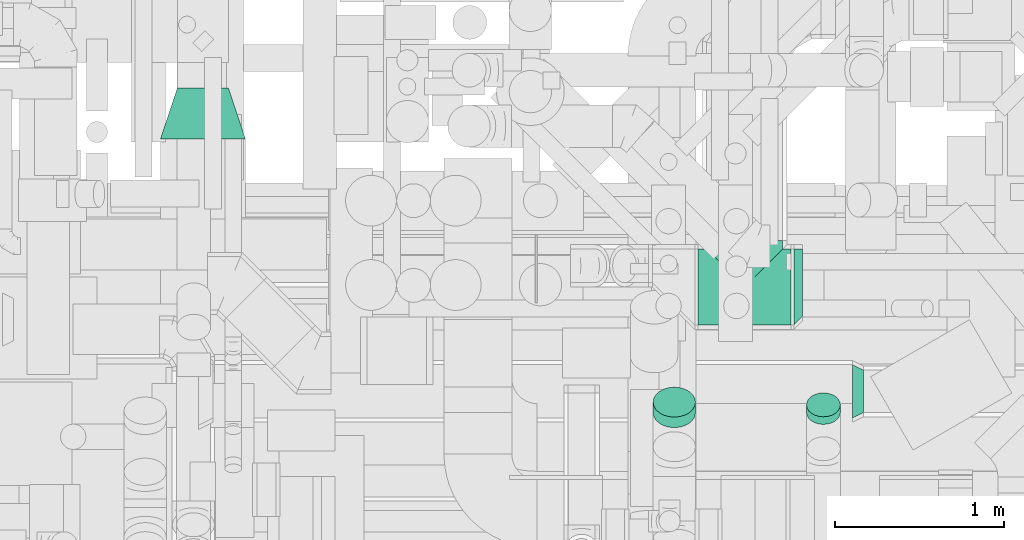
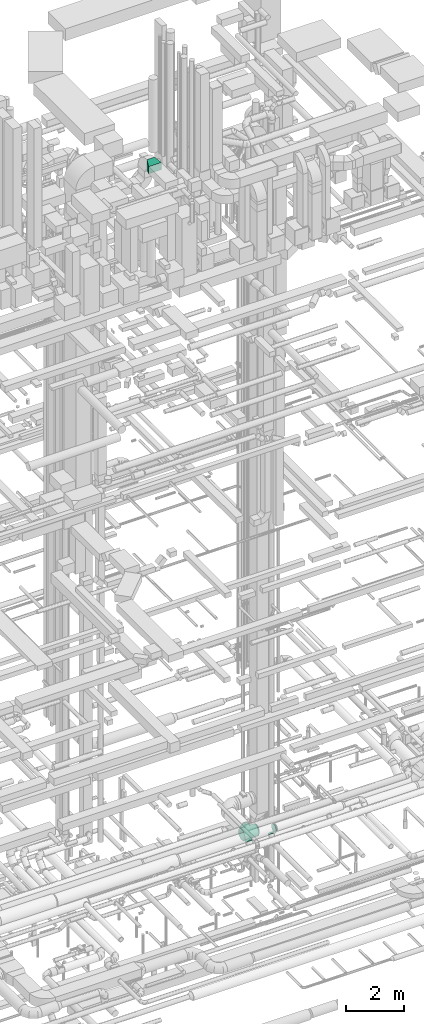
# One storey, part 327 of 337: 6 flow fittings.
"""IFC2X3 building model written with IfcOpenShell, lengths in millimetres."""

from ifc_helpers import new_model, entity, si_unit, converted_unit, derived_unit, direction, frame, origin, place, context, subcontext, project, spatial, faceted_brep, source, transform, mapped, material, type_object, type_shapes, element, save


model = new_model("IFC2X3")

# Units and contexts
model_context = context("Model", 3, precision=0.01, world=origin(), true_north=direction((6.12303176911189e-17, 1.0)))
body_context = subcontext(model_context, "Body", "Model", "MODEL_VIEW")
ifc_project = project(units=[si_unit("LENGTHUNIT", "METRE", prefix="MILLI"), si_unit("AREAUNIT", "SQUARE_METRE"), si_unit("VOLUMEUNIT", "CUBIC_METRE"), converted_unit("PLANEANGLEUNIT", "DEGREE", entity("IfcRatioMeasure", 0.0174532925199433), si_unit("PLANEANGLEUNIT", "RADIAN"), dimensions=[0, 0, 0, 0, 0, 0, 0]), si_unit("MASSUNIT", "GRAM", prefix="KILO"), derived_unit("MASSDENSITYUNIT", [(si_unit("MASSUNIT", "GRAM", prefix="KILO"), 1), (si_unit("LENGTHUNIT", "METRE"), -3)]), derived_unit("MOMENTOFINERTIAUNIT", [(si_unit("LENGTHUNIT", "METRE"), 4)]), si_unit("TIMEUNIT", "SECOND"), si_unit("FREQUENCYUNIT", "HERTZ"), si_unit("THERMODYNAMICTEMPERATUREUNIT", "DEGREE_CELSIUS"), derived_unit("THERMALTRANSMITTANCEUNIT", [(si_unit("MASSUNIT", "GRAM", prefix="KILO"), 1), (si_unit("THERMODYNAMICTEMPERATUREUNIT", "KELVIN"), -1), (si_unit("TIMEUNIT", "SECOND"), -3)]), derived_unit("VOLUMETRICFLOWRATEUNIT", [(si_unit("LENGTHUNIT", "METRE"), 3), (si_unit("TIMEUNIT", "SECOND"), -1)]), derived_unit("MASSFLOWRATEUNIT", [(si_unit("MASSUNIT", "GRAM", prefix="KILO"), 1), (si_unit("TIMEUNIT", "SECOND"), -1)]), derived_unit("ROTATIONALFREQUENCYUNIT", [(si_unit("TIMEUNIT", "SECOND"), -1)]), si_unit("ELECTRICCURRENTUNIT", "AMPERE"), si_unit("ELECTRICVOLTAGEUNIT", "VOLT"), si_unit("POWERUNIT", "WATT"), si_unit("FORCEUNIT", "NEWTON", prefix="KILO"), si_unit("ILLUMINANCEUNIT", "LUX"), si_unit("LUMINOUSFLUXUNIT", "LUMEN"), si_unit("LUMINOUSINTENSITYUNIT", "CANDELA"), derived_unit("USERDEFINED", [(si_unit("MASSUNIT", "GRAM", prefix="KILO"), -1), (si_unit("LENGTHUNIT", "METRE"), -2), (si_unit("TIMEUNIT", "SECOND"), 3), (si_unit("LUMINOUSFLUXUNIT", "LUMEN"), 1)]), derived_unit("LINEARVELOCITYUNIT", [(si_unit("LENGTHUNIT", "METRE"), 1), (si_unit("TIMEUNIT", "SECOND"), -1)]), si_unit("PRESSUREUNIT", "PASCAL"), derived_unit("USERDEFINED", [(si_unit("LENGTHUNIT", "METRE"), -2), (si_unit("MASSUNIT", "GRAM", prefix="KILO"), 1), (si_unit("TIMEUNIT", "SECOND"), -2)]), derived_unit("LINEARFORCEUNIT", [(si_unit("MASSUNIT", "GRAM", prefix="KILO"), 1), (si_unit("LENGTHUNIT", "METRE"), 1), (si_unit("TIMEUNIT", "SECOND"), -2), (si_unit("LENGTHUNIT", "METRE"), -1)]), derived_unit("PLANARFORCEUNIT", [(si_unit("MASSUNIT", "GRAM", prefix="KILO"), 1), (si_unit("LENGTHUNIT", "METRE"), 1), (si_unit("TIMEUNIT", "SECOND"), -2), (si_unit("LENGTHUNIT", "METRE"), -2)])], contexts=[model_context])

# Site, building, storey
site_placement = place(None, origin())
site = spatial("IfcSite", under=ifc_project, at=site_placement, CompositionType="ELEMENT")
building_placement = place(site_placement, origin())
building = spatial("IfcBuilding", under=site, at=building_placement, CompositionType="ELEMENT")
storey_placement = place(building_placement, origin())
storey = spatial("IfcBuildingStorey", under=building, at=storey_placement, CompositionType="ELEMENT", Elevation=0.0)

# Flow fittings
ifc_material = material()
duct_fitting_type_1 = type_object("IfcDuctFittingType", PredefinedType="NOTDEFINED", material=ifc_material)
shared_shape_1 = source(origin(), body_context, "Body", "Brep", [
    faceted_brep([(130.94, 0.0, -225.0), (275.0, -50.07, -219.36), (45.41, -45.41, -220.37), (275.0, -97.62, -202.72), (75.2, -75.2, -212.06), (132.04, -132.04, -182.18), (275.0, -140.29, -175.91), (145.33, -145.33, -171.77), (118.32, -118.32, -191.38), (104.22, -104.22, -199.4), (89.84, -89.84, -206.29), (275.0, 0.0, -225.0), (-275.0, 0.0, -225.0), (-130.94, 0.0, -225.0), (-275.0, -50.07, -219.36), (15.18, -15.18, -224.49), (30.33, -30.33, -222.95), (60.38, -60.38, -216.75), (201.38, -201.38, -100.36), (275.0, -189.32, -118.95), (275.0, -202.72, -97.62), (275.0, -219.36, -50.07), (216.05, -216.05, -62.81), (275.0, -211.04, -73.85), (275.0, -225.0, 0.0), (225.0, -225.0, 0.0), (223.98, -223.98, -21.43), (-225.0, -225.0, 0.0), (-275.0, -225.0, 0.0), (-223.98, -223.98, -21.43), (181.57, -181.57, -132.88), (192.01, -192.01, -117.28), (275.0, -222.18, -25.03), (220.95, -220.95, -42.48), (209.46, -209.46, -82.17), (170.21, -170.21, -147.15), (275.0, -175.91, -140.29), (158.09, -158.09, -160.1), (0.0, 0.0, -225.0), (-15.18, -15.18, -224.49), (223.98, -223.98, 21.43), (-223.98, -223.98, 21.43), (275.0, -222.18, 25.03), (275.0, -219.36, 50.07), (220.95, -220.95, 42.48), (275.0, -211.04, 73.85), (275.0, -202.72, 97.62), (209.46, -209.46, 82.17), (216.05, -216.05, 62.81), (275.0, -175.91, 140.29), (181.57, -181.57, 132.88), (275.0, -189.32, 118.95), (30.33, -30.33, 222.95), (130.94, 0.0, 225.0), (15.18, -15.18, 224.49), (201.38, -201.38, 100.36), (192.01, -192.01, 117.28), (158.09, -158.09, 160.1), (170.21, -170.21, 147.15), (275.0, -140.29, 175.91), (145.33, -145.33, 171.77), (132.04, -132.04, 182.18), (118.32, -118.32, 191.38), (75.2, -75.2, 212.06), (275.0, -97.62, 202.72), (275.0, -50.07, 219.36), (104.22, -104.22, 199.4), (275.0, 0.0, 225.0), (-275.0, 0.0, 225.0), (-275.0, -50.07, 219.36), (-130.94, 0.0, 225.0), (89.84, -89.84, 206.29), (60.38, -60.38, 216.75), (45.41, -45.41, 220.37), (0.0, 0.0, 225.0), (-15.18, -15.18, 224.49), (225.0, -275.0, 0.0), (222.18, -275.0, 25.03), (219.36, -275.0, 50.07), (211.04, -275.0, 73.85), (202.72, -275.0, 97.62), (189.32, -275.0, 118.95), (175.91, -275.0, 140.29), (140.29, -275.0, 175.91), (97.62, -275.0, 202.72), (50.07, -275.0, 219.36), (0.0, -275.0, 225.0), (-50.07, -275.0, 219.36), (-97.62, -275.0, 202.72), (-140.29, -275.0, 175.91), (-175.91, -275.0, 140.29), (-189.32, -275.0, 118.95), (-202.72, -275.0, 97.62), (-211.04, -275.0, 73.85), (-219.36, -275.0, 50.07), (-222.18, -275.0, 25.03), (-225.0, -275.0, 0.0), (-222.18, -275.0, -25.03), (-219.36, -275.0, -50.07), (-211.04, -275.0, -73.85), (-202.72, -275.0, -97.62), (-189.32, -275.0, -118.95), (-175.91, -275.0, -140.29), (-140.29, -275.0, -175.91), (-97.62, -275.0, -202.72), (-50.07, -275.0, -219.36), (0.0, -275.0, -225.0), (50.07, -275.0, -219.36), (97.62, -275.0, -202.72), (140.29, -275.0, -175.91), (175.91, -275.0, -140.29), (189.32, -275.0, -118.95), (202.72, -275.0, -97.62), (211.04, -275.0, -73.85), (219.36, -275.0, -50.07), (222.18, -275.0, -25.03), (0.0, -130.94, 225.0), (0.0, -130.94, -225.0), (-45.41, -45.41, -220.37), (-75.2, -75.2, -212.06), (-132.04, -132.04, -182.18), (-145.33, -145.33, -171.77), (-118.32, -118.32, -191.38), (-104.22, -104.22, -199.4), (-89.84, -89.84, -206.29), (-30.33, -30.33, -222.95), (-60.38, -60.38, -216.75), (-201.38, -201.38, -100.36), (-216.05, -216.05, -62.81), (-181.57, -181.57, -132.88), (-192.01, -192.01, -117.28), (-220.95, -220.95, -42.48), (-209.46, -209.46, -82.17), (-170.21, -170.21, -147.15), (-158.09, -158.09, -160.1), (-220.95, -220.95, 42.48), (-209.46, -209.46, 82.17), (-216.05, -216.05, 62.81), (-181.57, -181.57, 132.88), (-30.33, -30.33, 222.95), (-201.38, -201.38, 100.36), (-192.01, -192.01, 117.28), (-158.09, -158.09, 160.1), (-170.21, -170.21, 147.15), (-145.33, -145.33, 171.77), (-132.04, -132.04, 182.18), (-118.32, -118.32, 191.38), (-75.2, -75.2, 212.06), (-104.22, -104.22, 199.4), (-89.84, -89.84, 206.29), (-60.38, -60.38, 216.75), (-45.41, -45.41, 220.37), (-275.0, -97.62, -202.72), (-275.0, -140.29, -175.91), (-275.0, -175.91, -140.29), (-275.0, -189.32, -118.95), (-275.0, -202.72, -97.62), (-275.0, -211.04, -73.85), (-275.0, -219.36, -50.07), (-275.0, -222.18, -25.03), (-275.0, -222.18, 25.03), (-275.0, -219.36, 50.07), (-275.0, -211.04, 73.85), (-275.0, -202.72, 97.62), (-275.0, -189.32, 118.95), (-275.0, -175.91, 140.29), (-275.0, -140.29, 175.91), (-275.0, -97.62, 202.72), (-275.0, 50.07, 219.36), (-275.0, 97.62, 202.72), (-275.0, 140.29, 175.91), (-275.0, 175.91, 140.29), (-275.0, 202.72, 97.62), (-275.0, 219.36, 50.07), (-275.0, 225.0, 0.0), (-275.0, 219.36, -50.07), (-275.0, 202.72, -97.62), (-275.0, 175.91, -140.29), (-275.0, 140.29, -175.91), (-275.0, 97.62, -202.72), (-275.0, 50.07, -219.36), (275.0, 225.0, 0.0), (275.0, 219.36, 50.07), (275.0, 202.72, 97.62), (275.0, 175.91, 140.29), (275.0, 140.29, 175.91), (275.0, 97.62, 202.72), (275.0, 50.07, 219.36), (275.0, 50.07, -219.36), (275.0, 97.62, -202.72), (275.0, 140.29, -175.91), (275.0, 175.91, -140.29), (275.0, 202.72, -97.62), (275.0, 219.36, -50.07)], [[[0, 1, 2]], [[3, 4, 1]], [[5, 6, 7]], [[6, 5, 8]], [[9, 3, 8]], [[8, 3, 6]], [[9, 10, 3]], [[11, 1, 0]], [[12, 13, 14]], [[15, 0, 16]], [[10, 4, 3]], [[17, 2, 1]], [[4, 17, 1]], [[0, 2, 16]], [[18, 19, 20]], [[21, 22, 23]], [[24, 25, 26]], [[27, 28, 29]], [[30, 19, 31]], [[21, 32, 33]], [[34, 23, 22]], [[26, 32, 24]], [[33, 22, 21]], [[30, 35, 36]], [[7, 6, 37]], [[35, 37, 36]], [[33, 32, 26]], [[34, 20, 23]], [[15, 38, 0]], [[38, 39, 13]], [[31, 19, 18]], [[34, 18, 20]], [[36, 19, 30]], [[37, 6, 36]], [[25, 24, 40]], [[27, 41, 28]], [[42, 43, 44]], [[40, 24, 42]], [[45, 46, 47]], [[48, 44, 43]], [[44, 40, 42]], [[49, 50, 51]], [[48, 43, 45]], [[52, 53, 54]], [[48, 45, 47]], [[55, 47, 46]], [[56, 51, 50]], [[57, 58, 49]], [[50, 49, 58]], [[46, 51, 55]], [[55, 51, 56]], [[49, 59, 57]], [[60, 59, 61]], [[59, 60, 57]], [[61, 59, 62]], [[63, 64, 65]], [[66, 62, 64]], [[64, 62, 59]], [[67, 53, 65]], [[68, 69, 70]], [[71, 66, 64]], [[72, 63, 65]], [[71, 64, 63]], [[73, 65, 53]], [[74, 54, 53]], [[75, 74, 70]], [[52, 73, 53]], [[72, 65, 73]], [[76, 77, 78, 79, 80, 81, 82, 83, 84, 85, 86, 87, 88, 89, 90, 91, 92, 93, 94, 95, 96, 97, 98, 99, 100, 101, 102, 103, 104, 105, 106, 107, 108, 109, 110, 111, 112, 113, 114, 115]], [[116, 85, 73]], [[84, 63, 85]], [[61, 83, 60]], [[83, 61, 62]], [[66, 84, 62]], [[62, 84, 83]], [[66, 71, 84]], [[86, 85, 116]], [[54, 116, 52]], [[71, 63, 84]], [[72, 73, 85]], [[63, 72, 85]], [[116, 73, 52]], [[55, 81, 80]], [[78, 48, 79]], [[76, 25, 40]], [[50, 81, 56]], [[78, 77, 44]], [[47, 79, 48]], [[40, 77, 76]], [[44, 48, 78]], [[50, 58, 82]], [[60, 83, 57]], [[58, 57, 82]], [[44, 77, 40]], [[47, 80, 79]], [[54, 74, 116]], [[56, 81, 55]], [[47, 55, 80]], [[82, 81, 50]], [[57, 83, 82]], [[76, 26, 25]], [[115, 114, 33]], [[26, 76, 115]], [[113, 112, 34]], [[22, 33, 114]], [[33, 26, 115]], [[110, 30, 111]], [[22, 114, 113]], [[16, 117, 15]], [[22, 113, 34]], [[18, 34, 112]], [[31, 111, 30]], [[37, 35, 110]], [[30, 110, 35]], [[112, 111, 18]], [[18, 111, 31]], [[110, 109, 37]], [[7, 109, 5]], [[109, 7, 37]], [[5, 109, 8]], [[4, 108, 107]], [[9, 8, 108]], [[108, 8, 109]], [[106, 117, 107]], [[10, 9, 108]], [[17, 4, 107]], [[10, 108, 4]], [[2, 107, 117]], [[38, 15, 117]], [[16, 2, 117]], [[17, 107, 2]], [[117, 105, 118]], [[104, 119, 105]], [[120, 103, 121]], [[103, 120, 122]], [[123, 104, 122]], [[122, 104, 103]], [[123, 124, 104]], [[106, 105, 117]], [[39, 117, 125]], [[124, 119, 104]], [[126, 118, 105]], [[119, 126, 105]], [[117, 118, 125]], [[127, 101, 100]], [[98, 128, 99]], [[96, 27, 29]], [[129, 101, 130]], [[98, 97, 131]], [[132, 99, 128]], [[29, 97, 96]], [[131, 128, 98]], [[129, 133, 102]], [[121, 103, 134]], [[133, 134, 102]], [[131, 97, 29]], [[132, 100, 99]], [[39, 38, 117]], [[130, 101, 127]], [[132, 127, 100]], [[102, 101, 129]], [[134, 103, 102]], [[27, 96, 41]], [[95, 94, 135]], [[41, 96, 95]], [[93, 92, 136]], [[137, 135, 94]], [[135, 41, 95]], [[90, 138, 91]], [[137, 94, 93]], [[139, 116, 75]], [[137, 93, 136]], [[140, 136, 92]], [[141, 91, 138]], [[142, 143, 90]], [[138, 90, 143]], [[92, 91, 140]], [[140, 91, 141]], [[90, 89, 142]], [[144, 89, 145]], [[89, 144, 142]], [[145, 89, 146]], [[147, 88, 87]], [[148, 146, 88]], [[88, 146, 89]], [[86, 116, 87]], [[149, 148, 88]], [[150, 147, 87]], [[149, 88, 147]], [[151, 87, 116]], [[74, 75, 116]], [[139, 151, 116]], [[150, 87, 151]], [[12, 14, 152, 153, 154, 155, 156, 157, 158, 159, 28, 160, 161, 162, 163, 164, 165, 166, 167, 69, 68, 168, 169, 170, 171, 172, 173, 174, 175, 176, 177, 178, 179, 180]], [[181, 182, 183, 184, 185, 186, 187, 67, 65, 64, 59, 49, 51, 46, 45, 43, 42, 24, 32, 21, 23, 20, 19, 36, 6, 3, 1, 11, 188, 189, 190, 191, 192, 193]], [[187, 168, 68, 70, 74, 53, 67]], [[169, 168, 187, 186]], [[186, 185, 170, 169]], [[172, 171, 184, 183]], [[173, 172, 183, 182]], [[174, 173, 182, 181]], [[185, 184, 171, 170]], [[181, 193, 175, 174]], [[193, 192, 176, 175]], [[177, 176, 192, 191]], [[191, 190, 178, 177]], [[179, 178, 190, 189]], [[180, 179, 189, 188]], [[188, 11, 0, 38, 13, 12, 180]], [[13, 125, 118]], [[118, 126, 14]], [[119, 124, 152]], [[126, 119, 14]], [[118, 14, 13]], [[119, 152, 14]], [[122, 153, 152]], [[120, 153, 122]], [[153, 120, 121]], [[122, 152, 123]], [[123, 152, 124]], [[134, 133, 154]], [[134, 154, 153]], [[130, 155, 129]], [[127, 132, 156]], [[125, 13, 39]], [[127, 156, 155]], [[133, 129, 154]], [[155, 154, 129]], [[132, 128, 157]], [[156, 132, 157]], [[128, 131, 158]], [[159, 158, 131]], [[29, 28, 159]], [[128, 158, 157]], [[159, 131, 29]], [[127, 155, 130]], [[134, 153, 121]], [[136, 140, 163]], [[136, 163, 162]], [[143, 142, 165]], [[138, 165, 164]], [[143, 165, 138]], [[135, 160, 41]], [[141, 164, 140]], [[138, 164, 141]], [[28, 41, 160]], [[161, 160, 135]], [[135, 137, 161]], [[161, 137, 162]], [[164, 163, 140]], [[136, 162, 137]], [[142, 166, 165]], [[147, 150, 69]], [[149, 147, 167]], [[139, 70, 151]], [[70, 139, 75]], [[150, 151, 69]], [[145, 146, 166]], [[144, 166, 142]], [[166, 144, 145]], [[146, 167, 166]], [[148, 167, 146]], [[148, 149, 167]], [[167, 147, 69]], [[69, 151, 70]]]),
])
type_shapes(duct_fitting_type_1, [shared_shape_1])
flow_fitting_1_placement = place(storey_placement, frame((57585.12, 9725.0, 3165.82), z_axis=(0.0, 0.0, 1.0), x_axis=(-1.0, 0.0, 0.0)))
element("IfcFlowFitting", 1, at=flow_fitting_1_placement, inside=storey, type_object=duct_fitting_type_1, material=ifc_material, context=body_context, shape_type="MappedRepresentation", body=[
    mapped(shared_shape_1, transform((0.0, 0.0, 0.0), scale=1.0)),
])
duct_fitting_type_2 = type_object("IfcDuctFittingType", PredefinedType="NOTDEFINED", material=ifc_material)
shared_shape_2 = source(origin(), body_context, "Body", "Brep", [
    faceted_brep([(50.0, -19.5, -192.77), (50.0, 25.0, -197.79), (50.0, 69.5, -192.77), (50.0, 111.78, -177.98), (50.0, 149.7, -154.15), (50.0, 181.37, -122.48), (50.0, 205.19, -84.56), (50.0, 219.99, -42.29), (50.0, 225.0, 2.21), (50.0, 219.99, 46.72), (50.0, 205.19, 88.99), (50.0, 181.37, 126.91), (50.0, 149.7, 158.58), (50.0, 111.78, 182.41), (50.0, 69.5, 197.2), (50.0, 25.0, 202.21), (50.0, -19.5, 197.2), (50.0, -61.78, 182.41), (50.0, -99.7, 158.58), (50.0, -131.37, 126.91), (50.0, -155.19, 88.99), (50.0, -169.99, 46.72), (50.0, -175.0, 2.21), (50.0, -169.99, -42.29), (50.0, -155.19, -84.56), (50.0, -131.37, -122.48), (50.0, -99.7, -154.15), (50.0, -61.78, -177.98), (0.0, -140.29, -175.91), (0.0, -175.91, -140.29), (0.0, -202.72, -97.62), (0.0, -219.36, -50.07), (0.0, -225.0, 0.0), (0.0, -219.36, 50.07), (0.0, -202.72, 97.62), (0.0, -175.91, 140.29), (0.0, -140.29, 175.91), (0.0, -97.62, 202.72), (0.0, -50.07, 219.36), (0.0, 0.0, 225.0), (0.0, 50.07, 219.36), (0.0, 97.62, 202.72), (0.0, 140.29, 175.91), (0.0, 175.91, 140.29), (0.0, 202.72, 97.62), (0.0, 219.36, 50.07), (0.0, 225.0, 0.0), (0.0, 219.36, -50.07), (0.0, 202.72, -97.62), (0.0, 175.91, -140.29), (0.0, 140.29, -175.91), (0.0, 97.62, -202.72), (0.0, 50.07, -219.36), (0.0, 0.0, -225.0), (0.0, -50.07, -219.36), (0.0, -97.62, -202.72), (20.14, 225.0, 0.89), (25.0, 213.08, 71.29), (20.42, 225.0, 0.9), (25.0, 192.43, 114.16), (25.0, 162.76, 151.37), (25.0, 82.68, 201.68), (20.14, 10.07, 215.82), (25.0, 125.56, 181.04), (22.77, 11.39, 214.62), (25.0, -57.68, 201.68), (25.0, -100.56, 181.04), (25.0, -137.76, 151.37), (25.0, -188.08, 71.29), (22.77, -202.23, 1.01), (25.0, -167.43, 114.16), (22.96, -202.04, 1.02), (25.0, -188.08, -69.08), (25.0, -167.43, -111.95), (25.0, -137.76, -149.15), (25.0, -57.68, -199.47), (22.96, 11.48, -212.5), (25.0, -100.56, -178.82), (20.42, 10.21, -213.89), (25.0, 82.68, -199.47), (25.0, 125.56, -178.82), (25.0, 162.76, -149.15), (25.0, 213.08, -69.08), (25.0, 192.43, -111.95)], [[[0, 1, 2, 3, 4, 5, 6, 7, 8, 9, 10, 11, 12, 13, 14, 15, 16, 17, 18, 19, 20, 21, 22, 23, 24, 25, 26, 27]], [[28, 29, 30, 31, 32, 33, 34, 35, 36, 37, 38, 39, 40, 41, 42, 43, 44, 45, 46, 47, 48, 49, 50, 51, 52, 53, 54, 55]], [[56, 45, 57]], [[9, 8, 58, 56]], [[56, 46, 45]], [[44, 43, 59]], [[10, 59, 11]], [[56, 57, 9]], [[45, 44, 57]], [[60, 59, 43]], [[57, 44, 59]], [[57, 59, 10]], [[57, 10, 9]], [[59, 60, 11]], [[60, 12, 11]], [[61, 40, 62]], [[63, 42, 41]], [[42, 60, 43]], [[61, 41, 40]], [[12, 63, 13]], [[14, 62, 64, 15]], [[40, 39, 62]], [[61, 63, 41]], [[63, 12, 60]], [[61, 13, 63]], [[62, 14, 61]], [[60, 42, 63]], [[13, 61, 14]], [[64, 38, 65]], [[17, 66, 18]], [[37, 36, 66]], [[64, 16, 15]], [[38, 64, 62, 39]], [[16, 65, 17]], [[38, 37, 65]], [[66, 65, 37]], [[67, 66, 36]], [[65, 66, 17]], [[65, 16, 64]], [[66, 67, 18]], [[67, 19, 18]], [[68, 33, 69]], [[70, 35, 34]], [[35, 67, 36]], [[68, 34, 33]], [[19, 70, 20]], [[21, 69, 71, 22]], [[33, 32, 69]], [[68, 70, 34]], [[70, 19, 67]], [[68, 20, 70]], [[69, 21, 68]], [[67, 35, 70]], [[20, 68, 21]], [[71, 31, 72]], [[24, 73, 25]], [[30, 29, 73]], [[71, 23, 22]], [[31, 71, 69, 32]], [[23, 72, 24]], [[31, 30, 72]], [[73, 72, 30]], [[74, 73, 29]], [[72, 73, 24]], [[72, 23, 71]], [[73, 74, 25]], [[74, 26, 25]], [[75, 54, 76]], [[77, 28, 55]], [[28, 74, 29]], [[75, 55, 54]], [[26, 77, 27]], [[76, 1, 0]], [[54, 53, 78, 76]], [[75, 77, 55]], [[77, 26, 74]], [[75, 27, 77]], [[76, 0, 75]], [[74, 28, 77]], [[27, 75, 0]], [[78, 52, 79]], [[2, 1, 76, 78]], [[78, 53, 52]], [[51, 50, 80]], [[3, 80, 4]], [[78, 79, 2]], [[52, 51, 79]], [[81, 80, 50]], [[79, 51, 80]], [[79, 80, 3]], [[79, 3, 2]], [[80, 81, 4]], [[81, 5, 4]], [[82, 47, 58]], [[83, 49, 48]], [[49, 81, 50]], [[82, 48, 47]], [[5, 83, 6]], [[58, 8, 7]], [[47, 46, 56, 58]], [[82, 83, 48]], [[83, 5, 81]], [[82, 6, 83]], [[58, 7, 82]], [[81, 49, 83]], [[6, 82, 7]]]),
])
type_shapes(duct_fitting_type_2, [shared_shape_2])
flow_fitting_2_placement = place(storey_placement, frame((57875.32, 9725.0, 3165.82)))
element("IfcFlowFitting", 2, at=flow_fitting_2_placement, inside=storey, type_object=duct_fitting_type_2, material=ifc_material, context=body_context, shape_type="MappedRepresentation", body=[
    mapped(shared_shape_2, transform((0.0, 0.0, 0.0), scale=1.0)),
])
duct_fitting_type_3 = type_object("IfcDuctFittingType", PredefinedType="NOTDEFINED", material=ifc_material)
shared_shape_3 = source(origin(), body_context, "Body", "Brep", [
    faceted_brep([(20.0, 25.88, -96.59), (20.0, 50.0, -86.6), (20.0, 70.71, -70.71), (20.0, 86.6, -50.0), (20.0, 96.59, -25.88), (20.0, 100.0, 0.0), (20.0, 96.59, 25.88), (20.0, 86.6, 50.0), (20.0, 70.71, 70.71), (20.0, 50.0, 86.6), (20.0, 25.88, 96.59), (20.0, 0.0, 100.0), (20.0, -25.88, 96.59), (20.0, -50.0, 86.6), (20.0, -70.71, 70.71), (20.0, -86.6, 50.0), (20.0, -96.59, 25.88), (20.0, -100.0, 0.0), (20.0, -96.59, -25.88), (20.0, -86.6, -50.0), (20.0, -70.71, -70.71), (20.0, -50.0, -86.6), (20.0, -25.88, -96.59), (20.0, 0.0, -100.0), (0.0, 0.0, 100.0), (0.0, 25.88, 96.59), (-43.36, 25.88, 96.59), (-43.36, 0.0, 100.0), (0.0, 50.0, 86.6), (-43.36, 50.0, 86.6), (0.0, 70.71, 70.71), (-43.36, 70.71, 70.71), (0.0, 86.6, 50.0), (0.0, 96.59, 25.88), (-43.36, 96.59, 25.88), (-43.36, 86.6, 50.0), (0.0, 100.0, 0.0), (-43.36, 100.0, 0.0), (0.0, 96.59, -25.88), (-43.36, 96.59, -25.88), (0.0, 86.6, -50.0), (-43.36, 86.6, -50.0), (0.0, 70.71, -70.71), (-43.36, 70.71, -70.71), (0.0, 50.0, -86.6), (0.0, 25.88, -96.59), (-43.36, 25.88, -96.59), (-43.36, 50.0, -86.6), (0.0, 0.0, -100.0), (-43.36, 0.0, -100.0), (0.0, -25.88, -96.59), (-43.36, -25.88, -96.59), (0.0, -50.0, -86.6), (-43.36, -50.0, -86.6), (0.0, -70.71, -70.71), (-43.36, -70.71, -70.71), (0.0, -86.6, -50.0), (0.0, -96.59, -25.88), (-43.36, -96.59, -25.88), (-43.36, -86.6, -50.0), (0.0, -100.0, 0.0), (-43.36, -100.0, 0.0), (0.0, -96.59, 25.88), (-43.36, -96.59, 25.88), (0.0, -86.6, 50.0), (-43.36, -86.6, 50.0), (0.0, -70.71, 70.71), (-43.36, -70.71, 70.71), (0.0, -50.0, 86.6), (0.0, -25.88, 96.59), (-43.36, -25.88, 96.59), (-43.36, -50.0, 86.6)], [[[0, 1, 2, 3, 4, 5, 6, 7, 8, 9, 10, 11, 12, 13, 14, 15, 16, 17, 18, 19, 20, 21, 22, 23]], [[24, 11, 10, 25, 26, 27]], [[25, 10, 9, 28, 29, 26]], [[28, 9, 8, 30, 31, 29]], [[32, 7, 6, 33, 34, 35]], [[33, 6, 5, 36, 37, 34]], [[30, 8, 7, 32, 35, 31]], [[36, 5, 4, 38, 39, 37]], [[38, 4, 3, 40, 41, 39]], [[40, 3, 2, 42, 43, 41]], [[44, 1, 0, 45, 46, 47]], [[45, 0, 23, 48, 49, 46]], [[42, 2, 1, 44, 47, 43]], [[48, 23, 22, 50, 51, 49]], [[50, 22, 21, 52, 53, 51]], [[52, 21, 20, 54, 55, 53]], [[56, 19, 18, 57, 58, 59]], [[57, 18, 17, 60, 61, 58]], [[54, 20, 19, 56, 59, 55]], [[60, 17, 16, 62, 63, 61]], [[62, 16, 15, 64, 65, 63]], [[64, 15, 14, 66, 67, 65]], [[68, 13, 12, 69, 70, 71]], [[69, 12, 11, 24, 27, 70]], [[66, 14, 13, 68, 71, 67]], [[49, 51, 53, 55, 59, 58, 61, 63, 65, 67, 71, 70, 27, 26, 29, 31, 35, 34, 37, 39, 41, 43, 47, 46]]]),
])
type_shapes(duct_fitting_type_3, [shared_shape_3])
flow_fitting_3_placement = place(storey_placement, frame((58050.32, 8998.53, 3387.43), z_axis=(0.0, 0.707162836835826, -0.707050721093124), x_axis=(0.0, -0.707050721093124, -0.707162836835826)))
element("IfcFlowFitting", 3, at=flow_fitting_3_placement, inside=storey, type_object=duct_fitting_type_3, material=ifc_material, context=body_context, shape_type="MappedRepresentation", body=[
    mapped(shared_shape_3, transform((0.0, 0.0, 0.0), scale=1.0)),
])
duct_fitting_type_4 = type_object("IfcDuctFittingType", PredefinedType="NOTDEFINED", material=ifc_material)
shared_shape_4 = source(origin(), body_context, "Body", "Brep", [
    faceted_brep([(20.0, 0.0, -125.0), (20.0, 32.35, -120.74), (20.0, 62.5, -108.25), (20.0, 88.39, -88.39), (20.0, 108.25, -62.5), (20.0, 120.74, -32.35), (20.0, 125.0, 0.0), (20.0, 120.74, 32.35), (20.0, 108.25, 62.5), (20.0, 88.39, 88.39), (20.0, 62.5, 108.25), (20.0, 32.35, 120.74), (20.0, 0.0, 125.0), (20.0, -32.35, 120.74), (20.0, -62.5, 108.25), (20.0, -88.39, 88.39), (20.0, -108.25, 62.5), (20.0, -120.74, 32.35), (20.0, -125.0, 0.0), (20.0, -120.74, -32.35), (20.0, -108.25, -62.5), (20.0, -88.39, -88.39), (20.0, -62.5, -108.25), (20.0, -32.35, -120.74), (0.0, 0.0, 125.0), (-67.78, 0.0, 125.0), (-67.78, -32.35, 120.74), (0.0, -32.35, 120.74), (-67.78, -62.5, 108.25), (0.0, -62.5, 108.25), (0.0, -88.39, 88.39), (-67.78, -88.39, 88.39), (0.0, -108.25, 62.5), (-67.78, -108.25, 62.5), (-67.78, -120.74, 32.35), (0.0, -120.74, 32.35), (-67.78, -125.0, 0.0), (0.0, -125.0, 0.0), (-67.78, -120.74, -32.35), (0.0, -120.74, -32.35), (-67.78, -108.25, -62.5), (0.0, -108.25, -62.5), (0.0, -88.39, -88.39), (-67.78, -88.39, -88.39), (0.0, -62.5, -108.25), (-67.78, -62.5, -108.25), (-67.78, -32.35, -120.74), (0.0, -32.35, -120.74), (-67.78, 0.0, -125.0), (0.0, 0.0, -125.0), (-67.78, 32.35, -120.74), (0.0, 32.35, -120.74), (-67.78, 62.5, -108.25), (0.0, 62.5, -108.25), (0.0, 88.39, -88.39), (-67.78, 88.39, -88.39), (0.0, 108.25, -62.5), (-67.78, 108.25, -62.5), (-67.78, 120.74, -32.35), (0.0, 120.74, -32.35), (-67.78, 125.0, 0.0), (0.0, 125.0, 0.0), (-67.78, 120.74, 32.35), (0.0, 120.74, 32.35), (-67.78, 108.25, 62.5), (0.0, 108.25, 62.5), (0.0, 88.39, 88.39), (-67.78, 88.39, 88.39), (0.0, 62.5, 108.25), (-67.78, 62.5, 108.25), (-67.78, 32.35, 120.74), (0.0, 32.35, 120.74)], [[[0, 1, 2, 3, 4, 5, 6, 7, 8, 9, 10, 11, 12, 13, 14, 15, 16, 17, 18, 19, 20, 21, 22, 23]], [[13, 12, 24, 25, 26, 27]], [[14, 13, 27, 26, 28, 29]], [[30, 15, 14, 29, 28, 31]], [[17, 16, 32, 33, 34, 35]], [[18, 17, 35, 34, 36, 37]], [[32, 16, 15, 30, 31, 33]], [[19, 18, 37, 36, 38, 39]], [[20, 19, 39, 38, 40, 41]], [[42, 21, 20, 41, 40, 43]], [[23, 22, 44, 45, 46, 47]], [[0, 23, 47, 46, 48, 49]], [[44, 22, 21, 42, 43, 45]], [[1, 0, 49, 48, 50, 51]], [[2, 1, 51, 50, 52, 53]], [[54, 3, 2, 53, 52, 55]], [[5, 4, 56, 57, 58, 59]], [[6, 5, 59, 58, 60, 61]], [[56, 4, 3, 54, 55, 57]], [[7, 6, 61, 60, 62, 63]], [[8, 7, 63, 62, 64, 65]], [[66, 9, 8, 65, 64, 67]], [[11, 10, 68, 69, 70, 71]], [[12, 11, 71, 70, 25, 24]], [[68, 10, 9, 66, 67, 69]], [[46, 45, 43, 40, 38, 36, 34, 33, 31, 28, 26, 25, 70, 69, 67, 64, 62, 60, 58, 57, 55, 52, 50, 48]]]),
])
type_shapes(duct_fitting_type_4, [shared_shape_4])
flow_fitting_4_placement = place(storey_placement, frame((57170.09, 8997.28, 3388.65), z_axis=(0.0, 0.707106781186579, -0.707106781186516), x_axis=(0.0, -0.707106781186516, -0.707106781186579)))
element("IfcFlowFitting", 4, at=flow_fitting_4_placement, inside=storey, type_object=duct_fitting_type_4, material=ifc_material, context=body_context, shape_type="MappedRepresentation", body=[
    mapped(shared_shape_4, transform((0.0, 0.0, 0.0), scale=1.0)),
])
duct_fitting_type_5 = type_object("IfcDuctFittingType", PredefinedType="NOTDEFINED", material=ifc_material)
shared_shape_5 = source(origin(), body_context, "Body", "Brep", [
    faceted_brep([(65.0, -73.47, -101.13), (65.0, -38.63, -118.88), (65.0, 0.0, -125.0), (65.0, 38.63, -118.88), (65.0, 73.47, -101.13), (65.0, 87.3, -87.3), (65.0, 101.13, -73.47), (65.0, 118.88, -38.63), (65.0, 125.0, 0.0), (65.0, 118.88, 38.63), (65.0, 101.13, 73.47), (65.0, 87.3, 87.3), (65.0, 73.47, 101.13), (65.0, 38.63, 118.88), (65.0, 0.0, 125.0), (65.0, -38.63, 118.88), (65.0, -73.47, 101.13), (65.0, -87.3, 87.3), (65.0, -101.13, 73.47), (65.0, -118.88, 38.63), (65.0, -125.0, 0.0), (65.0, -118.88, -38.63), (65.0, -101.13, -73.47), (65.0, -87.3, -87.3), (0.0, 152.13, -40.76), (0.0, 136.4, -78.75), (0.0, 111.37, -111.37), (0.0, 78.75, -136.4), (0.0, 40.76, -152.13), (0.0, 0.0, -157.5), (0.0, -40.76, -152.13), (0.0, -78.75, -136.4), (0.0, -111.37, -111.37), (0.0, -136.4, -78.75), (0.0, -152.13, -40.76), (0.0, -157.5, 0.0), (0.0, -152.13, 40.76), (0.0, -136.4, 78.75), (0.0, -111.37, 111.37), (0.0, -78.75, 136.4), (0.0, -40.76, 152.13), (0.0, 0.0, 157.5), (0.0, 40.76, 152.13), (0.0, 78.75, 136.4), (0.0, 111.37, 111.37), (0.0, 136.4, 78.75), (0.0, 152.13, 40.76), (0.0, 157.5, 0.0), (37.55, 136.1, 26.89), (28.39, 143.3, 0.0), (30.13, 131.59, 54.51), (31.67, 117.38, 79.32), (28.39, 0.0, 143.3), (37.55, 26.89, 136.1), (30.13, 54.51, 131.59), (32.04, 100.04, 100.04), (31.67, 79.32, 117.38), (37.55, -26.89, 136.1), (30.13, -54.51, 131.59), (31.67, -79.32, 117.38), (28.39, -143.3, 0.0), (37.55, -136.1, 26.89), (30.13, -131.59, 54.51), (32.04, -100.04, 100.04), (31.67, -117.38, 79.32), (37.55, -136.1, -26.89), (30.13, -131.59, -54.51), (31.67, -117.38, -79.32), (28.39, 0.0, -143.3), (37.55, -26.89, -136.1), (30.13, -54.51, -131.59), (32.04, -100.04, -100.04), (31.67, -79.32, -117.38), (37.55, 26.89, -136.1), (30.13, 54.51, -131.59), (31.67, 79.32, -117.38), (37.55, 136.1, -26.89), (30.13, 131.59, -54.51), (32.04, 100.04, -100.04), (31.67, 117.38, -79.32)], [[[0, 1, 2, 3, 4, 5, 6, 7, 8, 9, 10, 11, 12, 13, 14, 15, 16, 17, 18, 19, 20, 21, 22, 23]], [[24, 25, 26, 27, 28, 29, 30, 31, 32, 33, 34, 35, 36, 37, 38, 39, 40, 41, 42, 43, 44, 45, 46, 47]], [[48, 8, 49, 47]], [[50, 45, 51]], [[46, 45, 50]], [[46, 50, 48]], [[47, 46, 48]], [[41, 52, 14, 53]], [[9, 50, 10]], [[48, 50, 9]], [[51, 10, 50]], [[54, 43, 42]], [[8, 48, 9]], [[14, 13, 53]], [[55, 51, 44]], [[43, 54, 56]], [[12, 54, 13]], [[54, 12, 56]], [[54, 53, 13]], [[56, 55, 44]], [[42, 53, 54]], [[45, 44, 51]], [[11, 10, 55, 12]], [[42, 41, 53]], [[44, 43, 56]], [[55, 10, 51]], [[12, 55, 56]], [[57, 14, 52, 41]], [[58, 39, 59]], [[40, 39, 58]], [[40, 58, 57]], [[41, 40, 57]], [[35, 60, 20, 61]], [[15, 58, 16]], [[57, 58, 15]], [[59, 16, 58]], [[62, 37, 36]], [[14, 57, 15]], [[20, 19, 61]], [[63, 59, 38]], [[37, 62, 64]], [[18, 62, 19]], [[62, 18, 64]], [[62, 61, 19]], [[64, 63, 38]], [[36, 61, 62]], [[39, 38, 59]], [[17, 16, 63, 18]], [[36, 35, 61]], [[38, 37, 64]], [[63, 16, 59]], [[18, 63, 64]], [[65, 20, 60, 35]], [[66, 33, 67]], [[34, 33, 66]], [[34, 66, 65]], [[35, 34, 65]], [[29, 68, 2, 69]], [[21, 66, 22]], [[65, 66, 21]], [[67, 22, 66]], [[70, 31, 30]], [[20, 65, 21]], [[2, 1, 69]], [[71, 67, 32]], [[31, 70, 72]], [[0, 70, 1]], [[70, 0, 72]], [[70, 69, 1]], [[72, 71, 32]], [[30, 69, 70]], [[33, 32, 67]], [[23, 22, 71, 0]], [[30, 29, 69]], [[32, 31, 72]], [[71, 22, 67]], [[0, 71, 72]], [[73, 2, 68, 29]], [[74, 27, 75]], [[28, 27, 74]], [[28, 74, 73]], [[29, 28, 73]], [[47, 49, 8, 76]], [[3, 74, 4]], [[73, 74, 3]], [[75, 4, 74]], [[77, 25, 24]], [[2, 73, 3]], [[8, 7, 76]], [[78, 75, 26]], [[25, 77, 79]], [[6, 77, 7]], [[77, 6, 79]], [[77, 76, 7]], [[79, 78, 26]], [[24, 76, 77]], [[27, 26, 75]], [[5, 4, 78, 6]], [[24, 47, 76]], [[26, 25, 79]], [[78, 4, 75]], [[6, 78, 79]]]),
])
type_shapes(duct_fitting_type_5, [shared_shape_5])
flow_fitting_5_placement = place(storey_placement, frame((58221.4, 9108.65, 3500.03)))
element("IfcFlowFitting", 5, at=flow_fitting_5_placement, inside=storey, type_object=duct_fitting_type_5, material=ifc_material, context=body_context, shape_type="MappedRepresentation", body=[
    mapped(shared_shape_5, transform((0.0, 0.0, 0.0), scale=1.0)),
])
duct_fitting_type_6 = type_object("IfcDuctFittingType", PredefinedType="NOTDEFINED", material=ifc_material)
shared_shape_6 = source(origin(), body_context, "Body", "Brep", [
    faceted_brep([(300.0, -150.0, 225.0), (300.0, -150.0, -225.0), (300.0, 150.0, -225.0), (300.0, 150.0, 225.0), (0.0, -250.0, 150.0), (0.0, 250.0, 150.0), (0.0, 250.0, -150.0), (0.0, -250.0, -150.0)], [[[0, 1, 2, 3]], [[4, 5, 6, 7]], [[4, 7, 1, 0]], [[7, 6, 2, 1]], [[6, 5, 3, 2]], [[5, 4, 0, 3]]]),
])
type_shapes(duct_fitting_type_6, [shared_shape_6])
flow_fitting_6_placement = place(storey_placement, frame((54388.0, 10599.6, 31550.0), z_axis=(0.0, 0.0, 1.0), x_axis=(0.0, 1.0, 0.0)))
element("IfcFlowFitting", 6, at=flow_fitting_6_placement, inside=storey, type_object=duct_fitting_type_6, material=ifc_material, context=body_context, shape_type="MappedRepresentation", body=[
    mapped(shared_shape_6, transform((0.0, 0.0, 0.0), scale=1.0)),
])

save(model, "model.ifc")
